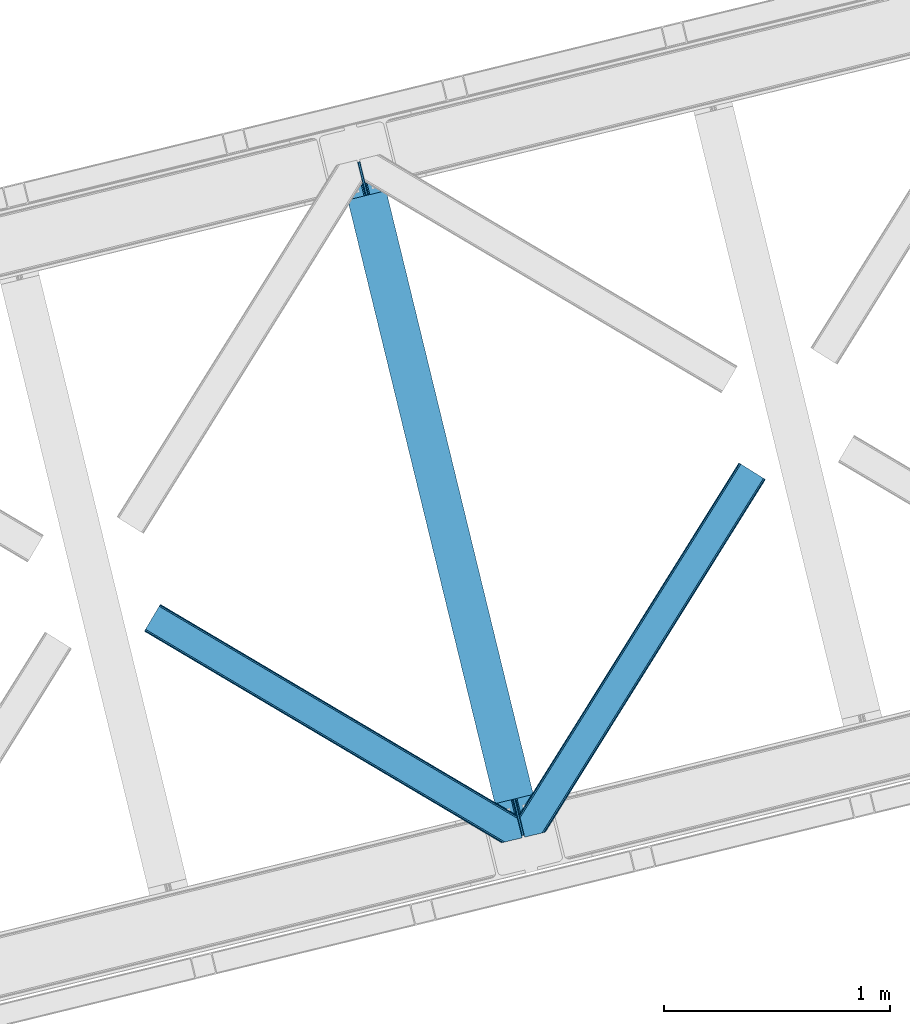
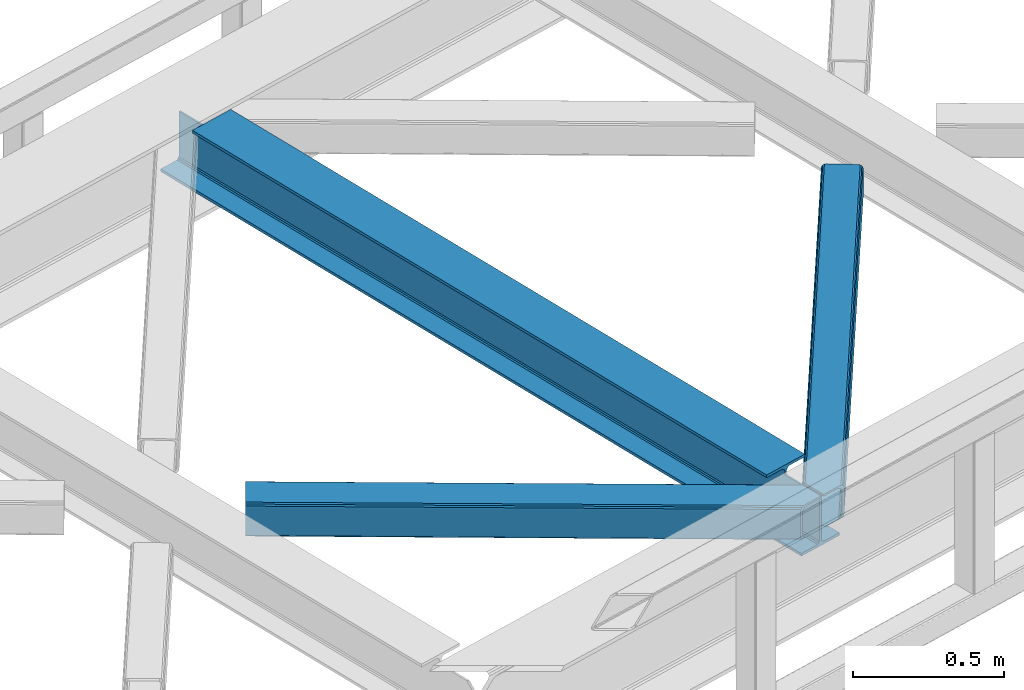
# One storey, part 69 of 92: 2 members, 1 beam.
"""IFC4 building model written with IfcOpenShell, lengths in millimetres."""

from ifc_helpers import new_model, entity, si_unit, converted_unit, derived_unit, direction, frame, origin, place, context, subcontext, project, spatial, triangles, polygons, material, type_object, element, save


model = new_model("IFC4")

# Units and contexts
model_context = context("Model", 3, precision=0.01, world=origin(), true_north=direction((6.12303176911189e-17, 1.0)))
plan_context = context("Plan", 3, precision=0.01, world=origin(), true_north=direction((6.12303176911189e-17, 1.0)))
body_context = subcontext(model_context, "Body", "Model", "MODEL_VIEW")
ifc_project = project(units=[si_unit("LENGTHUNIT", "METRE", prefix="MILLI"), si_unit("AREAUNIT", "SQUARE_METRE"), si_unit("VOLUMEUNIT", "CUBIC_METRE"), converted_unit("PLANEANGLEUNIT", "DEGREE", entity("IfcRatioMeasure", 0.0174532925199433), si_unit("PLANEANGLEUNIT", "RADIAN"), dimensions=[0, 0, 0, 0, 0, 0, 0]), si_unit("MASSUNIT", "GRAM", prefix="KILO"), derived_unit("MASSDENSITYUNIT", [(si_unit("MASSUNIT", "GRAM", prefix="KILO"), 1), (si_unit("LENGTHUNIT", "METRE"), -3)]), derived_unit("MOMENTOFINERTIAUNIT", [(si_unit("LENGTHUNIT", "METRE"), 4)]), si_unit("TIMEUNIT", "SECOND"), si_unit("FREQUENCYUNIT", "HERTZ"), si_unit("THERMODYNAMICTEMPERATUREUNIT", "DEGREE_CELSIUS"), derived_unit("THERMALTRANSMITTANCEUNIT", [(si_unit("MASSUNIT", "GRAM", prefix="KILO"), 1), (si_unit("THERMODYNAMICTEMPERATUREUNIT", "KELVIN"), -1), (si_unit("TIMEUNIT", "SECOND"), -3)]), derived_unit("VOLUMETRICFLOWRATEUNIT", [(si_unit("LENGTHUNIT", "METRE"), 3), (si_unit("TIMEUNIT", "SECOND"), -1)]), derived_unit("MASSFLOWRATEUNIT", [(si_unit("MASSUNIT", "GRAM", prefix="KILO"), 1), (si_unit("TIMEUNIT", "SECOND"), -1)]), derived_unit("ROTATIONALFREQUENCYUNIT", [(si_unit("TIMEUNIT", "SECOND"), -1)]), si_unit("ELECTRICCURRENTUNIT", "AMPERE"), si_unit("ELECTRICVOLTAGEUNIT", "VOLT"), si_unit("POWERUNIT", "WATT"), si_unit("FORCEUNIT", "NEWTON", prefix="KILO"), si_unit("ILLUMINANCEUNIT", "LUX"), si_unit("LUMINOUSFLUXUNIT", "LUMEN"), si_unit("LUMINOUSINTENSITYUNIT", "CANDELA"), derived_unit("USERDEFINED", [(si_unit("MASSUNIT", "GRAM", prefix="KILO"), -1), (si_unit("LENGTHUNIT", "METRE"), -2), (si_unit("TIMEUNIT", "SECOND"), 3), (si_unit("LUMINOUSFLUXUNIT", "LUMEN"), 1)]), derived_unit("LINEARVELOCITYUNIT", [(si_unit("LENGTHUNIT", "METRE"), 1), (si_unit("TIMEUNIT", "SECOND"), -1)]), si_unit("PRESSUREUNIT", "PASCAL"), derived_unit("USERDEFINED", [(si_unit("LENGTHUNIT", "METRE"), -2), (si_unit("MASSUNIT", "GRAM", prefix="KILO"), 1), (si_unit("TIMEUNIT", "SECOND"), -2)]), derived_unit("LINEARFORCEUNIT", [(si_unit("MASSUNIT", "GRAM", prefix="KILO"), 1), (si_unit("LENGTHUNIT", "METRE"), 1), (si_unit("TIMEUNIT", "SECOND"), -2), (si_unit("LENGTHUNIT", "METRE"), -1)]), derived_unit("PLANARFORCEUNIT", [(si_unit("MASSUNIT", "GRAM", prefix="KILO"), 1), (si_unit("LENGTHUNIT", "METRE"), 1), (si_unit("TIMEUNIT", "SECOND"), -2), (si_unit("LENGTHUNIT", "METRE"), -2)])], contexts=[model_context, plan_context])

# Site, building, storey
site_placement = place(None, origin())
site = spatial("IfcSite", under=ifc_project, at=site_placement, CompositionType="ELEMENT")
building_placement = place(site_placement, origin())
building = spatial("IfcBuilding", under=site, at=building_placement, CompositionType="ELEMENT")
storey_placement = place(building_placement, frame((0.0, 0.0, 15900.0)))
storey = spatial("IfcBuildingStorey", under=building, at=storey_placement, Name="05", CompositionType="ELEMENT", Elevation=15900.0)

# Beam
ifc_material = material(Name="Metal painted (White)")
beam_type = type_object("IfcBeamType", PredefinedType="BEAM")
beam_placement = place(storey_placement, frame((-14893.79, 14164.41, 3441.0)))
element("IfcBeam", 1, at=beam_placement, inside=storey, type_object=beam_type, material=ifc_material, ObjectType="Steel Beam", PredefinedType="BEAM", context=body_context, shape_type="Tessellation", body=[
    polygons([(896.722476515616, 41.4445662733103, 11.000000000004), (896.722476515616, 41.4445662733103, 2.16573425859679e-12), (170.021610174763, 3022.65205668042, 2.16573425859679e-12), (170.021610174765, 3022.65205668042, 11.000000000004), (830.656936561993, 25.3403919499678, 11.000000000004), (103.956070221139, 3006.54788235708, 11.000000000004), (824.708186540698, 23.8903211957396, 12.2179274798217), (98.007320199847, 3005.09781160285, 12.2179274798217), (819.665079784591, 22.6610105689216, 15.686291501017), (92.9642134437449, 3003.86850097603, 15.686291501017), (816.295383581409, 21.8396114687119, 20.8770650821657), (89.5945172405603, 3003.04710187582, 20.8770650821657), (815.11210363173, 21.5511744621206, 27.0000000000047), (88.4112372908766, 3002.75866486923, 27.0000000000047), (81.6103728838758, 3001.1008822183, 27.0000000000047), (81.6103728838779, 3001.1008822183, 203.000000000006), (88.4112372908766, 3002.75866486923, 203.000000000006), (0.0, 2981.20749040711, 2.16573425859679e-12), (2.16573425859679e-12, 2981.20749040711, 10.9999999999997), (66.0655399536129, 2997.31166473045, 11.000000000004), (72.0142899749184, 2998.76173548469, 12.2179274798217), (77.057396731027, 2999.9910461115, 15.6862915010192), (80.4270929342029, 3000.81244521171, 20.8770650821657), (815.11210363173, 21.5511744621227, 203.000000000006), (808.311239224731, 19.8933918111897, 203.000000000006), (808.311239224727, 19.8933918111876, 27.0000000000047), (807.127959275054, 19.6049548046006, 20.8770650821657), (803.758263071878, 18.783555704393, 15.6862915010192), (798.715156315769, 17.5542450775707, 12.2179274798217), (792.766406294466, 16.1041743233447, 11.000000000004), (726.700866340851, 0.0, 10.9999999999997), (726.700866340851, 2.16573425859679e-12, 2.16573425859679e-12), (775.945201911958, 182.229070489532, 203.069792164282), (124.290390378913, 2855.5685280608, 203.000000000006), (124.513271168061, 2854.65418562638, 203.617301946336), (124.526185412587, 2854.60120565348, 217.000003693143), (775.799998669233, 182.824605273258, 217.000003676718), (775.800869277129, 182.821033832379, 204.00000679514), (769.234900758912, 180.199471824632, 203.006342981088), (769.012053092185, 181.11382383896, 203.617301946336), (768.999138847661, 181.166803811854, 217.000003693143), (117.725325591011, 2852.94340419208, 217.000003676718), (117.724454983119, 2852.94697563296, 204.00000679514), (117.580155394069, 2853.53894853353, 203.076120467494), (117.489525971919, 2853.91074540987, 203.000000000006), (776.983483393262, 183.112202246699, 223.122939328039), (780.352479801942, 183.936472070578, 228.313710402595), (785.395115205966, 185.167716295884, 231.782072735464), (791.343694076674, 186.618489150565, 232.999999602236), (857.409144942199, 202.723028934499, 232.999999283132), (857.407671605762, 202.729072911373, 243.999994005812), (687.38629070184, 161.283566114484, 243.999994827032), (687.38776403828, 161.277522137611, 233.000000104353), (753.453214903793, 177.382061921543, 232.999999785253), (759.402120032138, 178.83149638977, 231.782072861012), (764.445684539262, 180.058929212905, 228.313710479427), (767.816071449003, 180.877494870334, 223.12293937232), (116.541840866981, 2852.65580721864, 223.122939328039), (113.172844458302, 2851.83153739476, 228.313710402595), (108.13020905428, 2850.60029316945, 231.782072735464), (102.181630183566, 2849.14952031477, 232.999999602236), (36.1161793180448, 2833.04498053084, 232.999999283128), (36.1176526544823, 2833.03893655396, 243.999994005812), (206.139033558403, 2874.48444335085, 243.999994827032), (206.137560221966, 2874.49048732773, 233.000000104357), (140.072109356442, 2858.38594754379, 232.999999785253), (134.12320422811, 2856.93651307557, 231.782072861012), (129.079639720982, 2855.70908025243, 228.313710479427), (125.709252811239, 2854.890514595, 223.12293937232)], [[[1, 2, 3, 4]], [[5, 1, 4, 6]], [[7, 5, 6, 8]], [[9, 7, 8, 10]], [[11, 9, 10, 12]], [[13, 11, 12, 14]], [[15, 16, 17, 14, 12, 10, 8, 6, 4, 3, 18, 19, 20, 21, 22, 23]], [[13, 24, 25, 26, 27, 28, 29, 30, 31, 32, 2, 1, 5, 7, 9, 11]], [[2, 32, 18, 3]], [[32, 31, 19, 18]], [[31, 30, 20, 19]], [[27, 26, 15, 23]], [[28, 27, 23, 22]], [[29, 28, 22, 21]], [[30, 29, 21, 20]], [[33, 24, 13, 14, 17, 34, 35, 36, 37, 38]], [[25, 39, 40, 41, 42, 43, 44, 16, 15, 26]], [[39, 25, 24, 33]], [[45, 34, 17, 16]], [[41, 40, 38, 37, 46, 47, 48, 49, 50, 51, 52, 53, 54, 55, 56, 57]], [[42, 58, 59, 60, 61, 62, 63, 64, 65, 66, 67, 68, 69, 36, 35, 43]], [[46, 37, 36, 69]], [[47, 46, 69, 68]], [[48, 47, 68, 67]], [[49, 48, 67, 66]], [[50, 49, 66, 65]], [[51, 50, 65, 64]], [[52, 51, 64, 63]], [[53, 52, 63, 62]], [[54, 53, 62, 61]], [[55, 54, 61, 60]], [[56, 55, 60, 59]], [[57, 56, 59, 58]], [[41, 57, 58, 42]]], closed=False),
])

# Members
member_type_1 = type_object("IfcMemberType", PredefinedType="BRACE")
member_1_placement = place(storey_placement, frame((-14098.67, 14177.81, 3510.0)))
element("IfcMember", 2, at=member_1_placement, inside=storey, type_object=member_type_1, ObjectType="Steel Horizontal Brace", PredefinedType="BRACE", context=body_context, shape_type="Tessellation", body=[
    triangles([(986.151434326172, 1647.42967529297, 0.0), (1075.22041625976, 1591.82725524902, 0.0), (119.789199829102, 259.603921508789, 0.0), (154.549868774413, 117.004486083984, 0.0), (115.90339050293, 275.545971679687, 4.52065429687718), (117.571893310547, 268.699877929686, 1.33247680664135), (158.435678100586, 101.063598632813, 4.52065429687718), (156.766012573242, 107.909692382813, 1.33247680664135), (114.825549316405, 275.743634033202, 5.52059326172093), (115.131344604491, 275.92385559082, 5.35316162109666), (158.132208251953, 99.1230194091786, 5.27525939941552), (115.440628051758, 276.108728027344, 5.18107910156323), (158.235690307616, 99.7787933349609, 5.02062377929906), (158.189181518554, 99.4822998046875, 5.13573303222802), (115.540621948241, 276.168026733398, 5.12526855468968), (115.687124633789, 275.922692871094, 4.88574829101708), (158.339172363281, 100.434567260741, 4.76482543945531), (158.032214355468, 98.4939880371094, 5.52059326172093), (1085.71744995117, 1585.27416687012, 5.12526855468968), (1080.90146484375, 1588.28096008301, 1.33247680664135), (1088.9358581543, 1583.26614990234, 10.8028289794929), (114.209307861327, 21.8533172607422, 10.8028289794929), (109.470062255859, 20.697573852538, 5.52059326172093), (1090.06485900879, 1582.56037902832, 17.5000946044929), (116.062683105469, 22.3044525146488, 17.5000946044929), (6.75075073242078, 102.619317626953, 5.52059326172093), (31.3620391845707, 1.65803833007703, 5.52059326172093), (1090.06485900879, 1582.56037902832, 122.500662231447), (116.062683105469, 22.3044525146488, 122.500662231447), (1088.9358581543, 1583.26614990234, 129.197927856447), (114.209307861327, 21.8533172607422, 129.197927856447), (1085.71744995117, 1585.27416687012, 134.874325561526), (108.936373901366, 20.5673492431633, 134.874325561526), (1080.90146484375, 1588.28096008301, 138.667117309571), (101.042669677734, 18.6430480957024, 138.667117309571), (1075.22041625976, 1591.82725524902, 139.999594116212), (91.7292846679684, 16.3734191894528, 139.999594116212), (980.470385742186, 1650.97597045899, 1.33247680664135), (975.654400634765, 1653.98276367187, 5.12526855468968), (1.68826904296839, 100.41131286621, 10.9621215820334), (972.43599243164, 1655.99194335938, 10.8028289794929), (971.306991577148, 1656.69655151367, 17.5000946044929), (0.239520263670784, 99.7787933349609, 12.5201660156272), (0.0, 100.761291503906, 17.5000946044929), (5.79266967773401, 76.9941375732415, 139.999594116212), (986.151434326172, 1647.42967529297, 139.999594116212), (24.5612915039055, 0.0, 139.999594116212), (971.306991577148, 1656.69655151367, 122.500662231447), (0.0, 100.761291503906, 122.500662231447), (980.470385742186, 1650.97597045899, 138.667117309571), (3.57652587890516, 86.088931274413, 138.667117309571), (975.654400634765, 1653.98276367187, 134.874325561526), (1.69640808105396, 93.8000885009769, 134.874325561526), (972.43599243164, 1655.99194335938, 129.197927856447), (0.44067077636646, 98.9520996093743, 129.197927856447), (29.9249176025387, 1.30805969238281, 6.99957275390625), (12.1969299316406, 74.0338531494144, 6.99957275390625), (8.9959625244137, 81.5496734619137, 8.3320495605476), (3.8869720458988, 84.8122650146488, 12.5201660156272), (1069.28589477539, 1595.53516845703, 6.99957275390625), (81.996157836913, 14.0014709472653, 6.99957275390625), (992.090606689453, 1643.72292480469, 6.99957275390625), (981.593572998047, 1650.27601318359, 12.1260040283232), (978.376327514648, 1652.28519287109, 17.8035644531265), (2.75797119140589, 89.4457031250004, 17.8035644531265), (986.410720825195, 1647.2692199707, 8.3320495605476), (977.24616394043, 1652.99096374512, 24.4996673583992), (2.31730041503943, 91.2548950195305, 24.4996673583992), (977.24616394043, 1652.99096374512, 115.501089477541), (2.31730041503943, 91.2548950195305, 115.501089477541), (4.01370849609339, 84.2936920166012, 127.87475280762), (2.75797119140589, 89.4457031250004, 122.196029663086), (5.89382629394458, 76.5825347900391, 131.667544555665), (8.10997009277344, 67.4877410888676, 133.000021362306), (24.5612915039055, 0.0, 133.000021362306), (978.376327514648, 1652.28519287109, 122.196029663086), (981.593572998047, 1650.27601318359, 127.87475280762), (986.410720825195, 1647.2692199707, 131.667544555665), (992.090606689453, 1643.72292480469, 133.000021362306), (1069.28589477539, 1595.53516845703, 133.000021362306), (81.996157836913, 14.0014709472653, 133.000021362306), (1079.78176574707, 1588.98208007813, 12.1260040283232), (1083.00017395019, 1586.97290039063, 17.8035644531265), (1084.13033752441, 1586.2671295166, 24.4996673583992), (1074.96578063965, 1591.98887329101, 8.3320495605476), (1079.78176574707, 1588.98208007813, 127.87475280762), (1084.13033752441, 1586.2671295166, 115.501089477541), (1083.00017395019, 1586.97290039063, 122.196029663086), (1074.96578063965, 1591.98887329101, 131.667544555665), (91.3095428466786, 16.2710998535149, 131.667544555665), (99.2032470703125, 18.1954010009758, 127.87475280762), (104.476181030273, 19.4802062988274, 122.196029663086), (106.329556274413, 19.9325042724613, 115.501089477541), (91.3095428466786, 16.2710998535149, 8.3320495605476), (104.476181030273, 19.4802062988274, 17.8035644531265), (99.2032470703125, 18.1954010009758, 12.1260040283232), (106.329556274413, 19.9325042724613, 24.4996673583992)], [[1, 2, 3], [4, 3, 2], [5, 3, 4], [3, 5, 6], [4, 7, 5], [7, 4, 8], [9, 10, 11], [10, 12, 13], [13, 14, 10], [12, 15, 16], [16, 17, 12], [16, 5, 7], [7, 17, 16], [17, 13, 12], [14, 11, 10], [11, 18, 9], [19, 14, 13], [13, 20, 19], [13, 17, 20], [17, 7, 20], [7, 8, 20], [21, 22, 18], [18, 19, 21], [14, 19, 11], [18, 11, 19], [22, 23, 18], [21, 24, 25], [25, 22, 21], [2, 20, 4], [8, 4, 20], [23, 26, 18], [23, 27, 26], [9, 18, 26], [24, 28, 29], [29, 25, 24], [28, 30, 29], [31, 29, 30], [30, 32, 31], [33, 31, 32], [32, 34, 33], [35, 33, 34], [34, 36, 35], [37, 35, 36], [38, 6, 5], [5, 39, 38], [39, 5, 16], [16, 15, 39], [40, 41, 9], [41, 39, 15], [15, 12, 41], [12, 9, 41], [42, 41, 40], [40, 43, 42], [43, 44, 42], [9, 26, 40], [38, 1, 6], [3, 6, 1], [36, 45, 37], [36, 46, 45], [45, 47, 37], [48, 42, 49], [44, 49, 42], [46, 50, 51], [51, 45, 46], [50, 52, 53], [53, 51, 50], [52, 54, 55], [55, 53, 52], [54, 48, 49], [49, 55, 54], [27, 56, 57], [26, 57, 58], [57, 26, 27], [59, 40, 26], [26, 58, 59], [43, 40, 59], [60, 57, 61], [60, 62, 57], [57, 56, 61], [63, 64, 65], [65, 59, 63], [66, 63, 59], [62, 66, 58], [58, 57, 62], [59, 58, 66], [64, 67, 68], [68, 65, 64], [67, 69, 70], [70, 68, 67], [71, 53, 72], [73, 74, 45], [74, 47, 45], [74, 75, 47], [51, 73, 45], [71, 51, 53], [71, 73, 51], [49, 68, 70], [55, 72, 53], [70, 72, 49], [72, 55, 49], [44, 68, 49], [43, 59, 65], [65, 68, 44], [44, 43, 65], [69, 76, 70], [72, 70, 76], [76, 77, 72], [71, 72, 77], [77, 78, 71], [73, 71, 78], [78, 79, 73], [74, 73, 79], [80, 74, 79], [74, 80, 81], [75, 74, 81], [21, 82, 83], [84, 28, 24], [21, 83, 24], [21, 19, 82], [83, 84, 24], [82, 19, 20], [60, 2, 1], [2, 85, 20], [85, 2, 60], [85, 82, 20], [30, 86, 32], [87, 28, 84], [28, 88, 30], [88, 28, 87], [30, 88, 86], [36, 80, 46], [34, 32, 86], [86, 89, 34], [89, 80, 36], [36, 34, 89], [63, 38, 39], [1, 62, 60], [1, 66, 62], [66, 1, 38], [63, 66, 38], [67, 42, 48], [41, 64, 63], [39, 41, 63], [64, 41, 42], [67, 64, 42], [50, 77, 52], [46, 80, 79], [79, 78, 46], [78, 77, 50], [50, 46, 78], [54, 52, 77], [48, 69, 67], [76, 48, 54], [48, 76, 69], [76, 54, 77], [35, 37, 90], [47, 81, 37], [81, 47, 75], [81, 90, 37], [91, 35, 90], [91, 33, 35], [33, 92, 31], [92, 33, 91], [29, 92, 93], [92, 29, 31], [61, 23, 94], [95, 96, 23], [96, 94, 23], [61, 27, 23], [27, 61, 56], [97, 95, 25], [22, 25, 95], [29, 97, 25], [97, 29, 93], [95, 23, 22], [80, 89, 90], [90, 81, 80], [89, 86, 91], [91, 90, 89], [86, 88, 92], [92, 91, 86], [88, 87, 93], [93, 92, 88], [87, 84, 97], [97, 93, 87], [84, 83, 97], [95, 97, 83], [83, 82, 95], [96, 95, 82], [82, 85, 96], [94, 96, 85], [85, 60, 94], [61, 94, 60]]),
])
member_type_2 = type_object("IfcMemberType", PredefinedType="BRACE")
member_2_placement = place(storey_placement, frame((-15757.99, 14152.66, 3510.0)))
element("IfcMember", 3, at=member_2_placement, inside=storey, type_object=member_type_2, ObjectType="Steel Horizontal Brace", PredefinedType="BRACE", context=body_context, shape_type="Tessellation", body=[
    triangles([(1468.20573120117, 208.966314697265, 0.0), (1502.96640014648, 66.3668792724602, 0.0), (8.91457214355432, 950.879168701171, 0.0), (62.4066558837894, 1041.23179321289, 0.0), (0.679028320311772, 936.966064453125, 10.8028289794929), (1582.93826293945, 0.542990112304324, 10.8679412841811), (1580.71514282227, 0.0, 17.5000946044929), (1509.32531433106, 44.5019348144524, 9.52034912109593), (2.6114685058601, 940.230981445313, 5.12526855468968), (1507.06266174316, 49.5609283447266, 5.12526855468968), (1507.93935241699, 45.9669616699211, 8.52041015625218), (1508.99045104981, 44.856564331054, 9.27850341796875), (1508.63000793457, 45.2344482421868, 9.02037963867406), (1508.27421569824, 45.6123321533196, 8.76225585937573), (1583.38939819336, 0.652285766600471, 9.52034912109593), (1505.18370666504, 57.2709228515614, 1.33247680664135), (5.50431518554615, 945.116729736328, 1.33247680664135), (0.0, 935.820785522461, 17.5000946044929), (1580.71514282227, 0.0, 122.500662231447), (0.0, 935.820785522461, 122.500662231447), (1595.73515625, 3.66140441894458, 138.667117309571), (1605.04737854004, 5.93219604492151, 139.999594116212), (8.91457214355432, 950.879168701171, 139.999594116212), (5.50431518554615, 945.116729736328, 138.667117309571), (1587.84028930664, 1.73710327148365, 134.874325561526), (2.6114685058601, 940.230981445313, 134.874325561526), (1582.56735534668, 0.452297973632085, 129.197927856447), (0.679028320311772, 936.966064453125, 129.197927856447), (1503.01058349609, 66.1843322753903, 8.52041015625218), (1503.36637573242, 65.0402160644517, 8.90294494629052), (1503.85704345703, 64.3216552734375, 9.10758361816625), (1504.35585021973, 63.5926300048814, 9.31571044922021), (1504.84651794434, 62.8740692138672, 9.52034912109593), (1602.20104064941, 5.23805236816406, 9.52034912109593), (9.07153930664026, 951.140780639647, 8.3320495605476), (1502.85826721191, 66.8075500488267, 8.42274169922166), (6.1786926269524, 946.255032348632, 12.1260040283232), (1597.57341613769, 4.11021423339844, 12.1260040283232), (1500.64909973144, 75.8732757568359, 6.99957275390625), (12.4829589843757, 956.903219604492, 6.99957275390625), (1592.30048217773, 2.82424621581958, 17.8035644531265), (4.24625244140589, 942.990115356444, 17.8035644531265), (1590.44826965332, 2.37311096191297, 24.4996673583992), (3.56838684081958, 941.84483642578, 24.4996673583992), (1470.52303161621, 199.45991821289, 6.99957275390625), (58.8429199218754, 1035.2089050293, 6.99957275390625), (1463.23394165039, 229.366232299804, 8.52041015625218), (1468.16154785156, 209.148861694335, 8.52041015625218), (1464.10946960449, 225.772265624999, 5.12526855468968), (1468.31386413574, 208.525643920897, 8.42274169922166), (1465.98958740234, 218.061108398437, 1.33247680664135), (1590.44826965332, 2.37311096191297, 115.501089477541), (3.56838684081958, 941.84483642578, 115.501089477541), (1592.30048217773, 2.82424621581958, 122.196029663086), (4.24625244140589, 942.990115356444, 122.196029663086), (1597.57341613769, 4.11021423339844, 127.87475280762), (6.1786926269524, 946.255032348632, 127.87475280762), (1605.46712036133, 6.03451538085938, 131.667544555665), (9.07153930664026, 951.140780639647, 131.667544555665), (1614.78050537109, 8.30414428710901, 133.000021362306), (12.4829589843757, 956.903219604492, 133.000021362306), (1672.2153717041, 22.304452514647, 139.999594116212), (1672.2153717041, 22.304452514647, 133.000021362306), (1653.44791259766, 99.2985900878903, 139.999594116212), (62.4066558837894, 1041.23179321289, 139.999594116212), (1655.7652130127, 89.7921936035145, 133.000021362306), (58.8429199218754, 1035.2089050293, 133.000021362306), (1648.09591369629, 121.256552124023, 129.197927856447), (1647.6540802002, 123.065744018553, 122.500662231447), (70.642199707032, 1055.14489746094, 129.197927856447), (71.3247161865238, 1056.29250183105, 122.500662231447), (1649.35165100098, 116.104541015624, 134.874325561526), (68.714410400391, 1051.88114318848, 134.874325561526), (1651.2306060791, 108.393383789062, 138.667117309571), (65.8215637207031, 1046.99539489746, 138.667117309571), (1647.6540802002, 123.065744018553, 17.5000946044929), (71.3247161865238, 1056.29250183105, 17.5000946044929), (70.642199707032, 1055.14489746094, 10.8028289794929), (65.1471862792969, 1045.85709228516, 12.1260040283232), (67.0796264648434, 1049.12200927734, 17.8035644531265), (67.7574920654297, 1050.26845092773, 24.4996673583992), (68.714410400391, 1051.88114318848, 5.12526855468968), (65.8215637207031, 1046.99539489746, 1.33247680664135), (62.254339599609, 1040.97250671387, 8.3320495605476), (65.1471862792969, 1045.85709228516, 127.87475280762), (67.7574920654297, 1050.26845092773, 115.501089477541), (67.0796264648434, 1049.12200927734, 122.196029663086), (62.254339599609, 1040.97250671387, 131.667544555665), (1649.97138061523, 113.558184814452, 24.4996673583992), (1649.97138061523, 113.558184814452, 115.501089477541), (1653.54790649414, 98.886987304686, 131.667544555665), (1651.66895141602, 106.59814453125, 127.87475280762), (1650.41321411133, 111.750155639647, 122.196029663086), (1650.50158081055, 111.386224365233, 17.8686767578147), (1650.60971374512, 110.944390869139, 16.5199218750022), (1647.66338195801, 123.028536987304, 16.5199218750022), (1641.37423095703, 124.97144165039, 10.8702667236357), (1463.45369567871, 229.701095581055, 9.22734375000073), (1463.34091186523, 229.532501220703, 8.87387695312646), (1464.25248413086, 229.406927490234, 9.52034912109593), (1639.87199707031, 125.435366821288, 9.52034912109593), (1646.38206481934, 109.727023315429, 12.1260040283232), (1468.73128051758, 211.034793090819, 9.52034912109593), (1644.35079345703, 107.0643951416, 9.52034912109593)], [[1, 2, 3], [3, 4, 1], [5, 6, 7], [6, 5, 8], [5, 9, 10], [10, 11, 5], [12, 5, 13], [12, 8, 5], [5, 14, 13], [5, 11, 14], [8, 15, 6], [16, 10, 9], [9, 17, 16], [2, 16, 17], [17, 3, 2], [7, 18, 5], [7, 19, 20], [20, 18, 7], [21, 22, 23], [23, 24, 21], [25, 21, 24], [24, 26, 25], [27, 25, 26], [26, 28, 27], [19, 27, 28], [28, 20, 19], [11, 29, 30], [14, 30, 31], [13, 31, 32], [12, 32, 33], [33, 8, 12], [32, 12, 13], [31, 13, 14], [30, 14, 11], [34, 15, 33], [8, 33, 15], [35, 30, 29], [32, 35, 33], [35, 32, 31], [30, 35, 31], [29, 36, 35], [37, 38, 33], [33, 35, 37], [38, 34, 33], [35, 36, 39], [39, 40, 35], [41, 38, 37], [37, 42, 41], [43, 41, 42], [42, 44, 43], [39, 45, 40], [46, 40, 45], [1, 45, 39], [47, 48, 49], [48, 50, 1], [45, 1, 50], [48, 51, 49], [48, 1, 51], [2, 1, 39], [2, 39, 36], [29, 2, 36], [11, 10, 29], [29, 16, 2], [29, 10, 16], [52, 43, 44], [44, 53, 52], [54, 52, 55], [53, 55, 52], [56, 54, 57], [55, 57, 54], [58, 56, 59], [57, 59, 56], [60, 58, 61], [59, 61, 58], [56, 58, 21], [25, 56, 21], [25, 27, 54], [56, 25, 54], [54, 27, 19], [58, 22, 21], [62, 60, 63], [62, 22, 60], [58, 60, 22], [54, 19, 52], [43, 7, 41], [19, 43, 52], [7, 6, 41], [19, 7, 43], [15, 41, 6], [38, 41, 15], [34, 38, 15], [22, 64, 23], [22, 62, 64], [65, 23, 64], [66, 60, 61], [60, 66, 63], [61, 67, 66], [68, 69, 70], [71, 70, 69], [72, 68, 73], [70, 73, 68], [74, 72, 75], [73, 75, 72], [64, 74, 65], [75, 65, 74], [69, 76, 71], [77, 71, 76], [78, 79, 80], [81, 71, 77], [78, 80, 77], [78, 82, 79], [80, 81, 77], [79, 82, 83], [46, 4, 3], [4, 84, 83], [84, 4, 46], [84, 79, 83], [70, 85, 73], [86, 71, 81], [71, 87, 70], [87, 71, 86], [70, 87, 85], [65, 67, 23], [75, 73, 85], [85, 88, 75], [88, 67, 65], [65, 75, 88], [37, 17, 9], [3, 40, 46], [3, 35, 40], [35, 3, 17], [37, 35, 17], [44, 18, 20], [5, 42, 37], [9, 5, 37], [42, 5, 18], [44, 42, 18], [24, 57, 26], [23, 67, 61], [61, 59, 23], [59, 57, 24], [24, 23, 59], [28, 26, 57], [20, 53, 44], [55, 20, 28], [20, 55, 53], [55, 28, 57], [89, 90, 81], [86, 81, 90], [91, 66, 67], [67, 88, 91], [92, 91, 88], [88, 85, 92], [93, 92, 85], [85, 87, 93], [90, 93, 87], [87, 86, 90], [92, 72, 74], [66, 91, 64], [91, 92, 74], [94, 95, 96], [63, 66, 62], [64, 62, 66], [91, 74, 64], [94, 76, 89], [69, 90, 89], [89, 76, 69], [94, 96, 76], [69, 93, 90], [93, 72, 92], [72, 93, 68], [69, 68, 93], [77, 76, 97], [76, 96, 97], [98, 99, 82], [47, 82, 99], [47, 49, 82], [78, 97, 100], [100, 82, 78], [100, 98, 82], [97, 101, 100], [51, 1, 4], [4, 83, 51], [49, 51, 83], [83, 82, 49], [97, 78, 77], [80, 79, 102], [102, 95, 80], [80, 94, 89], [46, 45, 50], [103, 102, 79], [103, 104, 102], [50, 79, 84], [50, 103, 79], [50, 84, 46], [89, 81, 80], [95, 94, 80], [96, 102, 97], [102, 96, 95], [102, 101, 97], [102, 104, 101], [101, 104, 103], [103, 100, 101]]),
])

save(model, "model.ifc")
